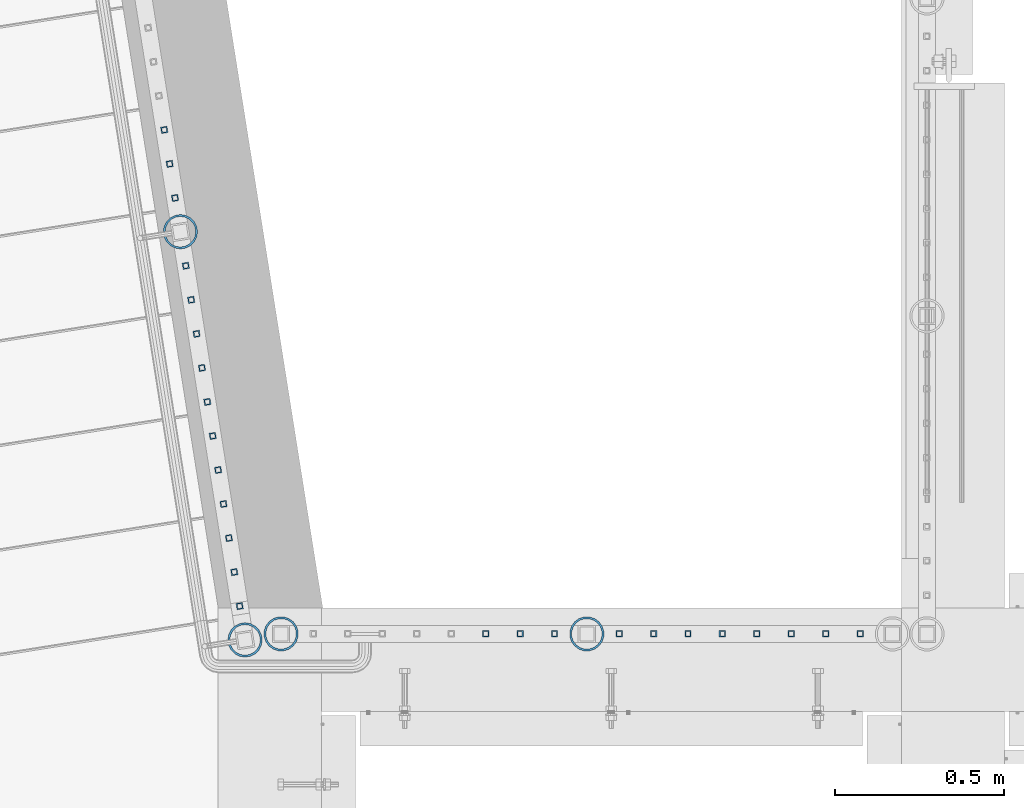
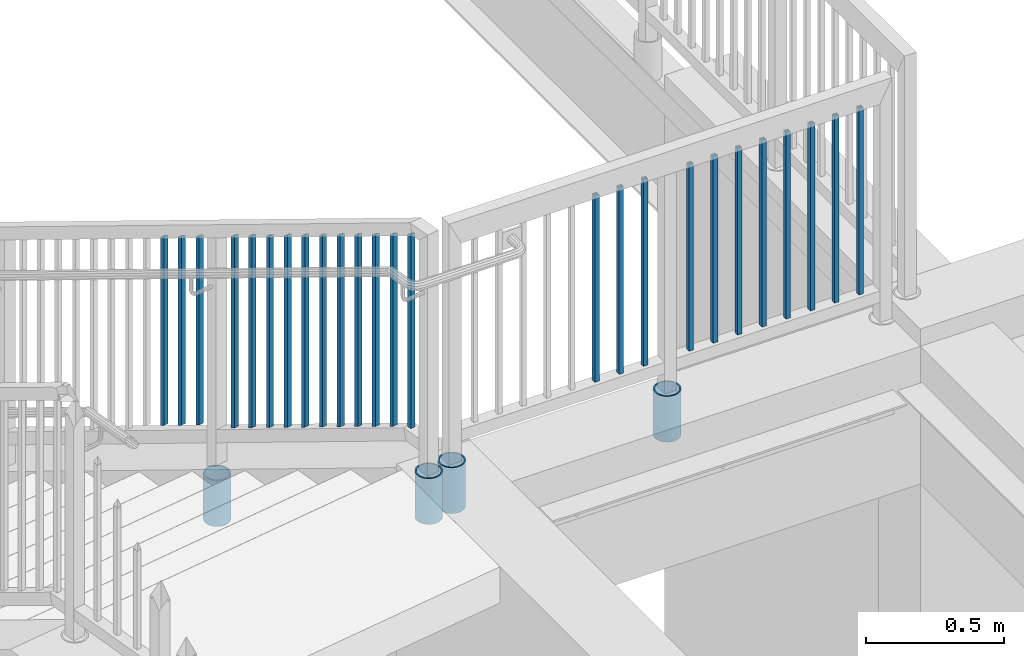
# One storey, part 211 of 975: 29 columns.
"""IFC2X3 building model written with IfcOpenShell, lengths in millimetres."""

from ifc_helpers import new_model, si_unit, frame, origin_with_axes, place, context, subcontext, project, spatial, faceted_brep, material, type_object, element, save


model = new_model("IFC2X3")

# Units and contexts
model_context = context("Model", 3, precision=1e-05, world=origin_with_axes())
body_context = subcontext(model_context, "Body", "Model", "MODEL_VIEW")
ifc_project = project(units=[si_unit("LENGTHUNIT", "METRE", prefix="MILLI"), si_unit("AREAUNIT", "SQUARE_METRE"), si_unit("VOLUMEUNIT", "CUBIC_METRE"), si_unit("MASSUNIT", "GRAM", prefix="KILO"), si_unit("TIMEUNIT", "SECOND"), si_unit("PLANEANGLEUNIT", "RADIAN"), si_unit("SOLIDANGLEUNIT", "STERADIAN"), si_unit("THERMODYNAMICTEMPERATUREUNIT", "DEGREE_CELSIUS"), si_unit("LUMINOUSINTENSITYUNIT", "LUMEN")], contexts=[model_context])

# Site, building, storey
site_placement = place(None, origin_with_axes())
site = spatial("IfcSite", under=ifc_project, at=site_placement, CompositionType="ELEMENT")
building_placement = place(site_placement, origin_with_axes())
building = spatial("IfcBuilding", under=site, at=building_placement, Name="Undefined", CompositionType="ELEMENT")
storey_placement = place(building_placement, origin_with_axes())
storey = spatial("IfcBuildingStorey", under=building, at=storey_placement, Name="Undefined", CompositionType="ELEMENT", Elevation=0.0)

# Columns
ifc_material_1 = material()
column_type_1 = type_object("IfcColumnType", Name="HSS3/4X3/4X.120_TUBES", PredefinedType="NOTDEFINED")
for number, where, z_axis, x_axis, name in (
    (1, (992.846988509125, 20672.3889447702, 4178.3000105335), (1.0, 0.0, 0.0), (0.0, 0.0, 1.0), "PICKET"),
    (2, (891.246988509125, 20672.3889447702, 4178.3000105335), (1.0, 0.0, 0.0), (0.0, 0.0, 1.0), "PICKET"),
    (3, (789.646988509125, 20672.3889447702, 4178.3000105335), (1.0, 0.0, 0.0), (0.0, 0.0, 1.0), "PICKET"),
    (4, (1183.56432177817, 20672.3889447702, 4178.3000162462), (1.0, 0.0, 0.0), (0.0, 0.0, 1.0), "PICKET"),
    (5, (1894.76432177817, 20672.3889447702, 4178.3000162462), (1.0, 0.0, 0.0), (0.0, 0.0, 1.0), "PICKET"),
    (6, (1793.16432177817, 20672.3889447702, 4178.3000162462), (1.0, 0.0, 0.0), (0.0, 0.0, 1.0), "PICKET"),
    (7, (1691.56432177817, 20672.3889447702, 4178.3000162462), (1.0, 0.0, 0.0), (0.0, 0.0, 1.0), "PICKET"),
    (8, (1589.96432177817, 20672.3889447702, 4178.3000162462), (1.0, 0.0, 0.0), (0.0, 0.0, 1.0), "PICKET"),
    (9, (1488.36432177817, 20672.3889447702, 4178.3000162462), (1.0, 0.0, 0.0), (0.0, 0.0, 1.0), "PICKET"),
    (10, (1386.76432177817, 20672.3889447702, 4178.3000162462), (1.0, 0.0, 0.0), (0.0, 0.0, 1.0), "PICKET"),
    (11, (1285.16432177817, 20672.3889447702, 4178.3000162462), (1.0, 0.0, 0.0), (0.0, 0.0, 1.0), "PICKET"),
):
    element("IfcColumn", number, at=place(storey_placement, frame(where, z_axis=z_axis, x_axis=x_axis)), inside=storey, type_object=column_type_1, material=ifc_material_1, Name=name, ObjectType="HSS3/4X3/4X.120_TUBES", context=body_context, shape_type="Brep", body=[
        faceted_brep([(0.0, 6.34999999998763, -6.34999999998763), (0.0, -6.35000000000582, -6.34999999998763), (825.49997943247, -6.35000000000582, -6.34999999998763), (825.49997943247, 6.34999999998763, -6.34999999998763), (0.0, -6.34999999998763, 6.34999999998763), (825.49997943247, -6.34999999998763, 6.34999999998763), (0.0, 6.35000000000946, 6.34999999998763), (825.49997943247, 6.35000000000946, 6.34999999998763), (0.0, 9.52499999997963, -9.52499999997963), (0.0, 9.52500000000873, 9.5249999999869), (825.49997943247, 9.52500000000873, 9.5249999999869), (825.49997943247, 9.52499999997963, -9.52499999997963), (0.0, -9.52499999997963, 9.52499999998327), (825.49997943247, -9.52499999997963, 9.52499999998327), (0.0, -9.52500000000873, -9.5249999999869), (825.49997943247, -9.52500000000873, -9.5249999999869)], [[[0, 1, 2, 3]], [[1, 4, 5, 2]], [[4, 6, 7, 5]], [[6, 0, 3, 7]], [[8, 9, 10, 11]], [[9, 12, 13, 10]], [[12, 14, 15, 13]], [[14, 8, 11, 15]], [[13, 15, 11, 10], [5, 7, 3, 2]], [[14, 12, 9, 8], [6, 4, 1, 0]]]),
    ])
for number, where, z_axis, x_axis, name in (
    (12, (-126.611819510976, 21958.5335003285, 3525.90359784302), (-0.987688340611262, -0.156434464938429, 0.0), (0.0, 0.0, 1.0), "PICKET"),
    (13, (-142.51441013771, 22058.9385051127, 3469.78070058239), (-0.987688340611262, -0.156434464938429, 0.0), (0.0, 0.0, 1.0), "PICKET"),
    (14, (-158.417000764441, 22159.3435098969, 3413.65780332177), (-0.987688340611262, -0.156434464938429, 0.0), (0.0, 0.0, 1.0), "PICKET"),
):
    element("IfcColumn", number, at=place(storey_placement, frame(where, z_axis=z_axis, x_axis=x_axis)), inside=storey, type_object=column_type_1, material=ifc_material_1, Name=name, ObjectType="HSS3/4X3/4X.120_TUBES", context=body_context, shape_type="Brep", body=[
        faceted_brep([(-3.50571911954194, 6.34999999999491, -6.34999999999809), (3.50573940444565, -6.34999999999491, -6.34999999999991), (838.195107257512, -6.34999999999491, -6.35000000000082), (831.183648729623, 6.34999999999491, -6.34999999999945), (3.50571915819046, -6.34999999998763, 6.34999999999786), (838.195107270213, -6.34999999999127, 6.34999999999809), (-3.50573936579713, 6.34999999999854, 6.34999999999968), (831.183648742323, 6.35000000000218, 6.34999999999945), (-5.25857868897492, 9.5249999999869, -9.52499999999668), (-5.25860905835771, 9.52500000000146, 9.52499999999964), (829.430784113527, 9.52499999999782, 9.52499999999964), (829.430784094476, 9.52499999999054, -9.52499999999827), (5.25857872762344, -9.52499999998327, 9.52499999999645), (839.947971905361, -9.5249999999869, 9.52499999999736), (5.25860909700623, -9.52499999999418, -9.52499999999986), (839.947971886309, -9.52499999999782, -9.525000000001)], [[[0, 1, 2, 3]], [[1, 4, 5, 2]], [[4, 6, 7, 5]], [[6, 0, 3, 7]], [[8, 9, 10, 11]], [[9, 12, 13, 10]], [[12, 14, 15, 13]], [[14, 8, 11, 15]], [[13, 15, 11, 10], [5, 7, 3, 2]], [[14, 12, 9, 8], [6, 4, 1, 0]]]),
    ])
column_1_placement = place(storey_placement, frame((64.1130818819122, 20754.3438757387, 4178.2999918998), z_axis=(-0.987688340611262, -0.156434464938429, 0.0), x_axis=(0.0, 0.0, 1.0)))
element("IfcColumn", 15, at=column_1_placement, inside=storey, type_object=column_type_1, material=ifc_material_1, Name="PICKET", ObjectType="HSS3/4X3/4X.120_TUBES", context=body_context, shape_type="Brep", body=[
    faceted_brep([(0.0, 6.34999999998763, -6.34999999998763), (0.0, -6.35000000000582, -6.34999999998763), (858.898731993615, -6.34999999999491, -6.35000000000082), (851.887273465725, 6.34999999999491, -6.349999999999), (0.0, -6.34999999998763, 6.34999999998763), (858.898732006316, -6.34999999999127, 6.34999999999809), (0.0, 6.35000000000946, 6.34999999998763), (851.887273478426, 6.34999999999854, 6.34999999999991), (0.0, 9.52499999997963, -9.52499999997963), (0.0, 9.52500000000873, 9.5249999999869), (850.134408849629, 9.52499999999782, 9.52499999999964), (850.134408830578, 9.5249999999869, -9.52499999999827), (0.0, -9.52499999997963, 9.52499999998327), (860.651596641464, -9.52499999998327, 9.52499999999782), (0.0, -9.52500000000873, -9.5249999999869), (860.651596622412, -9.52499999999782, -9.52500000000055)], [[[0, 1, 2, 3]], [[1, 4, 5, 2]], [[4, 6, 7, 5]], [[6, 0, 3, 7]], [[8, 9, 10, 11]], [[9, 12, 13, 10]], [[12, 14, 15, 13]], [[14, 8, 11, 15]], [[13, 15, 11, 10], [5, 7, 3, 2]], [[14, 12, 9, 8], [6, 4, 1, 0]]]),
])
for number, where, z_axis, x_axis, name in (
    (16, (48.2104912543862, 20854.7488805279, 4142.88071913312), (-0.987688340611262, -0.156434464938429, 0.0), (0.0, 0.0, 1.0), "PICKET"),
    (17, (32.3079006276537, 20955.153885312, 4086.7578218725), (-0.987688340611262, -0.156434464938429, 0.0), (0.0, 0.0, 1.0), "PICKET"),
    (18, (16.4053100009201, 21055.5588900962, 4030.63492461188), (-0.987688340611262, -0.156434464938429, 0.0), (0.0, 0.0, 1.0), "PICKET"),
    (19, (0.502719374190065, 21155.9638948803, 3974.51202735126), (-0.987688340611262, -0.156434464938429, 0.0), (0.0, 0.0, 1.0), "PICKET"),
    (20, (-15.3998712525421, 21256.3688996645, 3918.38913009064), (-0.987688340611262, -0.156434464938429, 0.0), (0.0, 0.0, 1.0), "PICKET"),
    (21, (-31.3024618794072, 21356.7739044495, 3862.26623283002), (-0.987688340611262, -0.156434464938429, 0.0), (0.0, 0.0, 1.0), "PICKET"),
    (22, (-47.2050525061386, 21457.1789092336, 3806.1433355694), (-0.987688340611262, -0.156434464938429, 0.0), (0.0, 0.0, 1.0), "PICKET"),
    (23, (-63.10764313287, 21557.5839140178, 3750.02043830879), (-0.987688340611262, -0.156434464938429, 0.0), (0.0, 0.0, 1.0), "PICKET"),
    (24, (-79.0102337596018, 21657.9889188019, 3693.89754104817), (-0.987688340611262, -0.156434464938429, 0.0), (0.0, 0.0, 1.0), "PICKET"),
    (25, (-94.9128243863345, 21758.3939235861, 3637.77464378755), (-0.987688340611262, -0.156434464938429, 0.0), (0.0, 0.0, 1.0), "PICKET"),
):
    element("IfcColumn", number, at=place(storey_placement, frame(where, z_axis=z_axis, x_axis=x_axis)), inside=storey, type_object=column_type_1, material=ifc_material_1, Name=name, ObjectType="HSS3/4X3/4X.120_TUBES", context=body_context, shape_type="Brep", body=[
        faceted_brep([(-17.9916664943412, 6.34999999999491, -6.34999999999945), (-10.9802079664514, -6.34999999999127, -6.35000000000173), (838.195107257512, -6.34999999999491, -6.35000000000082), (831.183648729623, 6.34999999999491, -6.34999999999945), (-10.9802079664505, -6.34999999998763, 6.34999999999764), (838.195107270213, -6.34999999999127, 6.34999999999809), (-17.9916664943403, 6.35000000000218, 6.34999999999945), (831.183648742323, 6.35000000000218, 6.34999999999945), (-19.7445311263136, 9.52499999999054, -9.52499999999918), (-19.7445311263118, 9.52500000000146, 9.52499999999918), (829.430784113527, 9.52499999999782, 9.52499999999964), (829.430784094476, 9.52499999999054, -9.52499999999827), (-9.22734333447806, -9.52499999998327, 9.52499999999691), (839.947971905361, -9.5249999999869, 9.52499999999736), (-9.22734333447897, -9.52499999999418, -9.525000000001), (839.947971886309, -9.52499999999782, -9.525000000001)], [[[0, 1, 2, 3]], [[1, 4, 5, 2]], [[4, 6, 7, 5]], [[6, 0, 3, 7]], [[8, 9, 10, 11]], [[9, 12, 13, 10]], [[12, 14, 15, 13]], [[14, 8, 11, 15]], [[13, 15, 11, 10], [5, 7, 3, 2]], [[14, 12, 9, 8], [6, 4, 1, 0]]]),
    ])
ifc_material_2 = material(Name="STEEL/A53")
column_type_2 = type_object("IfcColumnType", Name="PIPE3-1/2STD", PredefinedType="NOTDEFINED")
column_2_placement = place(storey_placement, frame((186.288333380988, 20672.4249713359, 3835.40001649977), z_axis=(-0.707106781186601, 0.707106781186494, 2.36468622460961e-14), x_axis=(0.0, 0.0, 1.0)))
element("IfcColumn", 26, at=column_2_placement, inside=storey, type_object=column_type_2, material=ifc_material_2, ObjectType="PIPE3-1/2STD", context=body_context, shape_type="Brep", body=[
    faceted_brep([(0.0, -45.0595999999932, 1.45519152283669e-11), (0.0, -42.8542262016344, 13.924182159768), (203.199999999991, -42.8542262017145, 13.9241821598171), (203.19999999999, -45.0596000000478, 5.82076609134674e-11), (0.0, -36.45398215971, 26.4853683542424), (203.199999999993, -36.45398215981, 26.4853683542988), (0.0, -26.4853683541623, 36.45398215979), (203.199999999995, -26.4853683542788, 36.4539821598537), (0.0, -13.9241821596988, 42.8542262017108), (203.199999999998, -13.9241821598262, 42.8542262017836), (0.0, 3.63797880709171e-11, 45.0596000000514), (203.2, -9.27684595808387e-11, 45.0596000001387), (0.0, 13.9241821597716, 42.8542262017036), (203.200000000003, 13.9241821596443, 42.8542262017927), (0.0, 26.4853683542242, 36.4539821597718), (203.200000000006, 26.4853683541096, 36.4539821598701), (0.0, 36.4539821597537, 26.4853683542206), (203.200000000008, 36.4539821596554, 26.4853683543224), (0.0, 42.8542262016563, 13.9241821597425), (203.200000000009, 42.8542262015817, 13.9241821598443), (0.0, 45.0595999999932, -1.09139364212751e-11), (203.200000000009, 45.0595999999423, 8.9130480773747e-11), (0.0, 42.8542262016344, -13.9241821597643), (203.200000000008, 42.854226201609, -13.9241821596697), (0.0, 36.45398215971, -26.4853683542387), (203.200000000007, 36.4539821597045, -26.4853683541514), (0.0, 26.4853683541623, -36.4539821597864), (203.200000000004, 26.4853683541733, -36.4539821597064), (0.0, 13.9241821596988, -42.8542262017072), (203.200000000002, 13.9241821597225, -42.8542262016381), (0.0, -3.63797880709171e-11, -45.0596000000478), (203.199999999999, -9.09494701772928e-12, -45.0595999999914), (0.0, -13.9241821597716, -42.8542262016963), (203.199999999996, -13.9241821597479, -42.8542262016472), (0.0, -26.4853683542242, -36.4539821597682), (203.199999999993, -26.4853683542133, -36.4539821597227), (0.0, -36.4539821597537, -26.4853683542169), (203.199999999992, -36.4539821597609, -26.4853683541751), (0.0, -42.8542262016563, -13.9241821597352), (203.199999999991, -42.8542262016872, -13.924182159697), (0.0, -50.799999999992, 1.81898940354586e-11), (0.0, -48.3136710278013, -15.6980633142484), (203.199999999989, -48.313671027825, -15.6980633142139), (203.199999999989, -50.8000000000466, 5.63886715099216e-11), (0.0, -41.0980633142644, -29.8594908164741), (203.19999999999, -41.0980633142663, -29.8594908164414), (0.0, -29.859490816485, -41.0980633142826), (203.199999999993, -29.8594908164687, -41.0980633142426), (0.0, -15.6980633142848, -48.313671027845), (203.199999999995, -15.6980633142539, -48.313671027794), (0.0, -4.36557456851006e-11, -50.8000000000575), (203.199999999998, -7.27595761418343e-12, -50.7999999999993), (0.0, 15.6980633142011, -48.3136710278523), (203.200000000002, 15.6980633142375, -48.3136710277831), (0.0, 29.8594908164159, -41.0980633143045), (203.200000000005, 29.8594908164378, -41.0980633142226), (0.0, 41.0980633142135, -29.8594908165032), (203.200000000008, 41.0980633142171, -29.8594908164141), (0.0, 48.3136710277722, -15.6980633142775), (203.200000000009, 48.3136710277504, -15.6980633141811), (0.0, 50.799999999992, -1.45519152283669e-11), (203.20000000001, 50.7999999999411, 9.09494701772928e-11), (0.0, 48.313671027794, 15.6980633142521), (203.20000000001, 48.3136710277213, 15.6980633143594), (0.0, 41.0980633142644, 29.8594908164814), (203.200000000008, 41.0980633141626, 29.8594908165887), (0.0, 29.859490816485, 41.0980633142863), (203.200000000007, 29.8594908163632, 41.0980633143899), (0.0, 15.6980633142848, 48.3136710278486), (203.200000000004, 15.6980633141484, 48.3136710279414), (0.0, 4.00177668780088e-11, 50.8000000000611), (203.200000000001, -9.82254277914762e-11, 50.8000000001466), (0.0, -15.6980633142011, 48.3136710278559), (203.199999999997, -15.698063314343, 48.3136710279305), (0.0, -29.8594908164159, 41.0980633143081), (203.199999999994, -29.8594908165433, 41.0980633143681), (0.0, -41.0980633142171, 29.8594908165069), (203.199999999992, -41.0980633143226, 29.8594908165596), (0.0, -48.3136710277722, 15.6980633142812), (203.19999999999, -48.3136710278559, 15.6980633143285)], [[[0, 1, 2, 3]], [[1, 4, 5, 2]], [[4, 6, 7, 5]], [[6, 8, 9, 7]], [[8, 10, 11, 9]], [[10, 12, 13, 11]], [[12, 14, 15, 13]], [[14, 16, 17, 15]], [[16, 18, 19, 17]], [[18, 20, 21, 19]], [[20, 22, 23, 21]], [[22, 24, 25, 23]], [[24, 26, 27, 25]], [[26, 28, 29, 27]], [[28, 30, 31, 29]], [[30, 32, 33, 31]], [[32, 34, 35, 33]], [[34, 36, 37, 35]], [[36, 38, 39, 37]], [[38, 0, 3, 39]], [[40, 41, 42, 43]], [[41, 44, 45, 42]], [[44, 46, 47, 45]], [[46, 48, 49, 47]], [[48, 50, 51, 49]], [[50, 52, 53, 51]], [[52, 54, 55, 53]], [[54, 56, 57, 55]], [[56, 58, 59, 57]], [[58, 60, 61, 59]], [[60, 62, 63, 61]], [[62, 64, 65, 63]], [[64, 66, 67, 65]], [[66, 68, 69, 67]], [[68, 70, 71, 69]], [[70, 72, 73, 71]], [[72, 74, 75, 73]], [[74, 76, 77, 75]], [[76, 78, 79, 77]], [[78, 40, 43, 79]], [[45, 47, 49, 51, 53, 55, 57, 59, 61, 63, 65, 67, 69, 71, 73, 75, 77, 79, 43, 42], [5, 7, 9, 11, 13, 15, 17, 19, 21, 23, 25, 27, 29, 31, 33, 35, 37, 39, 3, 2]], [[78, 76, 74, 72, 70, 68, 66, 64, 62, 60, 58, 56, 54, 52, 50, 48, 46, 44, 41, 40], [38, 36, 34, 32, 30, 28, 26, 24, 22, 20, 18, 16, 14, 12, 10, 8, 6, 4, 1, 0]]]),
])
column_3_placement = place(storey_placement, frame((1088.20566786924, 20672.3889673828, 3835.40001649977), z_axis=(-0.707106781186601, 0.707106781186494, 2.36468622460961e-14), x_axis=(0.0, 0.0, 1.0)))
element("IfcColumn", 27, at=column_3_placement, inside=storey, type_object=column_type_2, material=ifc_material_2, ObjectType="PIPE3-1/2STD", context=body_context, shape_type="Brep", body=[
    faceted_brep([(0.0, -45.0595999999932, 1.45519152283669e-11), (0.0, -42.8542262016344, 13.924182159768), (203.199999999991, -42.8542262017145, 13.9241821598171), (203.19999999999, -45.0596000000478, 5.82076609134674e-11), (0.0, -36.45398215971, 26.4853683542424), (203.199999999993, -36.45398215981, 26.4853683542988), (0.0, -26.4853683541623, 36.45398215979), (203.199999999995, -26.4853683542788, 36.4539821598537), (0.0, -13.9241821596988, 42.8542262017108), (203.199999999998, -13.9241821598262, 42.8542262017836), (0.0, 3.63797880709171e-11, 45.0596000000514), (203.2, -9.27684595808387e-11, 45.0596000001387), (0.0, 13.9241821597716, 42.8542262017036), (203.200000000003, 13.9241821596443, 42.8542262017927), (0.0, 26.4853683542242, 36.4539821597718), (203.200000000006, 26.4853683541096, 36.4539821598701), (0.0, 36.4539821597537, 26.4853683542206), (203.200000000008, 36.4539821596554, 26.4853683543224), (0.0, 42.8542262016563, 13.9241821597425), (203.200000000009, 42.8542262015817, 13.9241821598443), (0.0, 45.0595999999932, -1.09139364212751e-11), (203.200000000009, 45.0595999999423, 8.9130480773747e-11), (0.0, 42.8542262016344, -13.9241821597643), (203.200000000008, 42.854226201609, -13.9241821596697), (0.0, 36.45398215971, -26.4853683542387), (203.200000000007, 36.4539821597045, -26.4853683541514), (0.0, 26.4853683541623, -36.4539821597864), (203.200000000004, 26.4853683541733, -36.4539821597064), (0.0, 13.9241821596988, -42.8542262017072), (203.200000000002, 13.9241821597225, -42.8542262016381), (0.0, -3.63797880709171e-11, -45.0596000000478), (203.199999999999, -9.09494701772928e-12, -45.0595999999914), (0.0, -13.9241821597716, -42.8542262016963), (203.199999999996, -13.9241821597479, -42.8542262016472), (0.0, -26.4853683542242, -36.4539821597682), (203.199999999993, -26.4853683542133, -36.4539821597227), (0.0, -36.4539821597537, -26.4853683542169), (203.199999999992, -36.4539821597609, -26.4853683541751), (0.0, -42.8542262016563, -13.9241821597352), (203.199999999991, -42.8542262016872, -13.924182159697), (0.0, -50.799999999992, 1.81898940354586e-11), (0.0, -48.3136710278013, -15.6980633142484), (203.199999999989, -48.313671027825, -15.6980633142139), (203.199999999989, -50.8000000000466, 5.63886715099216e-11), (0.0, -41.0980633142644, -29.8594908164741), (203.19999999999, -41.0980633142663, -29.8594908164414), (0.0, -29.859490816485, -41.0980633142826), (203.199999999993, -29.8594908164687, -41.0980633142426), (0.0, -15.6980633142848, -48.313671027845), (203.199999999995, -15.6980633142539, -48.313671027794), (0.0, -4.36557456851006e-11, -50.8000000000575), (203.199999999998, -7.27595761418343e-12, -50.7999999999993), (0.0, 15.6980633142011, -48.3136710278523), (203.200000000002, 15.6980633142375, -48.3136710277831), (0.0, 29.8594908164159, -41.0980633143045), (203.200000000005, 29.8594908164378, -41.0980633142226), (0.0, 41.0980633142135, -29.8594908165032), (203.200000000008, 41.0980633142171, -29.8594908164141), (0.0, 48.3136710277722, -15.6980633142775), (203.200000000009, 48.3136710277504, -15.6980633141811), (0.0, 50.799999999992, -1.45519152283669e-11), (203.20000000001, 50.7999999999411, 9.09494701772928e-11), (0.0, 48.313671027794, 15.6980633142521), (203.20000000001, 48.3136710277213, 15.6980633143594), (0.0, 41.0980633142644, 29.8594908164814), (203.200000000008, 41.0980633141626, 29.8594908165887), (0.0, 29.859490816485, 41.0980633142863), (203.200000000007, 29.8594908163632, 41.0980633143899), (0.0, 15.6980633142848, 48.3136710278486), (203.200000000004, 15.6980633141484, 48.3136710279414), (0.0, 4.00177668780088e-11, 50.8000000000611), (203.200000000001, -9.82254277914762e-11, 50.8000000001466), (0.0, -15.6980633142011, 48.3136710278559), (203.199999999997, -15.698063314343, 48.3136710279305), (0.0, -29.8594908164159, 41.0980633143081), (203.199999999994, -29.8594908165433, 41.0980633143681), (0.0, -41.0980633142171, 29.8594908165069), (203.199999999992, -41.0980633143226, 29.8594908165596), (0.0, -48.3136710277722, 15.6980633142812), (203.19999999999, -48.3136710278559, 15.6980633143285)], [[[0, 1, 2, 3]], [[1, 4, 5, 2]], [[4, 6, 7, 5]], [[6, 8, 9, 7]], [[8, 10, 11, 9]], [[10, 12, 13, 11]], [[12, 14, 15, 13]], [[14, 16, 17, 15]], [[16, 18, 19, 17]], [[18, 20, 21, 19]], [[20, 22, 23, 21]], [[22, 24, 25, 23]], [[24, 26, 27, 25]], [[26, 28, 29, 27]], [[28, 30, 31, 29]], [[30, 32, 33, 31]], [[32, 34, 35, 33]], [[34, 36, 37, 35]], [[36, 38, 39, 37]], [[38, 0, 3, 39]], [[40, 41, 42, 43]], [[41, 44, 45, 42]], [[44, 46, 47, 45]], [[46, 48, 49, 47]], [[48, 50, 51, 49]], [[50, 52, 53, 51]], [[52, 54, 55, 53]], [[54, 56, 57, 55]], [[56, 58, 59, 57]], [[58, 60, 61, 59]], [[60, 62, 63, 61]], [[62, 64, 65, 63]], [[64, 66, 67, 65]], [[66, 68, 69, 67]], [[68, 70, 71, 69]], [[70, 72, 73, 71]], [[72, 74, 75, 73]], [[74, 76, 77, 75]], [[76, 78, 79, 77]], [[78, 40, 43, 79]], [[45, 47, 49, 51, 53, 55, 57, 59, 61, 63, 65, 67, 69, 71, 73, 75, 77, 79, 43, 42], [5, 7, 9, 11, 13, 15, 17, 19, 21, 23, 25, 27, 29, 31, 33, 35, 37, 39, 3, 2]], [[78, 76, 74, 72, 70, 68, 66, 64, 62, 60, 58, 56, 54, 52, 50, 48, 46, 44, 41, 40], [38, 36, 34, 32, 30, 28, 26, 24, 22, 20, 18, 16, 14, 12, 10, 8, 6, 4, 1, 0]]]),
])
column_4_placement = place(storey_placement, frame((-110.816149070635, 21858.7988122083, 3162.29993752722), z_axis=(0.587785252279345, 0.809016994384486, -8.09014238711826e-10), x_axis=(0.0, 0.0, 1.0)))
element("IfcColumn", 28, at=column_4_placement, inside=storey, type_object=column_type_2, material=ifc_material_2, ObjectType="PIPE3-1/2STD", context=body_context, shape_type="Brep", body=[
    faceted_brep([(0.0, -45.0595999999932, 1.45519152283669e-11), (0.0, -42.8542262016344, 13.924182159768), (203.199999999991, -42.8542262017145, 13.9241821598171), (203.19999999999, -45.0596000000478, 5.82076609134674e-11), (0.0, -36.45398215971, 26.4853683542424), (203.199999999993, -36.45398215981, 26.4853683542988), (0.0, -26.4853683541623, 36.45398215979), (203.199999999995, -26.4853683542788, 36.4539821598537), (0.0, -13.9241821596988, 42.8542262017108), (203.199999999998, -13.9241821598262, 42.8542262017836), (0.0, 3.63797880709171e-11, 45.0596000000514), (203.2, -9.27684595808387e-11, 45.0596000001387), (0.0, 13.9241821597716, 42.8542262017036), (203.200000000003, 13.9241821596443, 42.8542262017927), (0.0, 26.4853683542242, 36.4539821597718), (203.200000000006, 26.4853683541096, 36.4539821598701), (0.0, 36.4539821597537, 26.4853683542206), (203.200000000008, 36.4539821596554, 26.4853683543224), (0.0, 42.8542262016563, 13.9241821597425), (203.200000000009, 42.8542262015817, 13.9241821598443), (0.0, 45.0595999999932, -1.09139364212751e-11), (203.200000000009, 45.0595999999423, 8.9130480773747e-11), (0.0, 42.8542262016344, -13.9241821597643), (203.200000000008, 42.854226201609, -13.9241821596697), (0.0, 36.45398215971, -26.4853683542387), (203.200000000007, 36.4539821597045, -26.4853683541514), (0.0, 26.4853683541623, -36.4539821597864), (203.200000000004, 26.4853683541733, -36.4539821597064), (0.0, 13.9241821596988, -42.8542262017072), (203.200000000002, 13.9241821597225, -42.8542262016381), (0.0, -3.63797880709171e-11, -45.0596000000478), (203.199999999999, -9.09494701772928e-12, -45.0595999999914), (0.0, -13.9241821597716, -42.8542262016963), (203.199999999996, -13.9241821597479, -42.8542262016472), (0.0, -26.4853683542242, -36.4539821597682), (203.199999999993, -26.4853683542133, -36.4539821597227), (0.0, -36.4539821597537, -26.4853683542169), (203.199999999992, -36.4539821597609, -26.4853683541751), (0.0, -42.8542262016563, -13.9241821597352), (203.199999999991, -42.8542262016872, -13.924182159697), (0.0, -50.799999999992, 1.81898940354586e-11), (0.0, -48.3136710278013, -15.6980633142484), (203.199999999989, -48.313671027825, -15.6980633142139), (203.199999999989, -50.8000000000466, 5.63886715099216e-11), (0.0, -41.0980633142644, -29.8594908164741), (203.19999999999, -41.0980633142663, -29.8594908164414), (0.0, -29.859490816485, -41.0980633142826), (203.199999999993, -29.8594908164687, -41.0980633142426), (0.0, -15.6980633142848, -48.313671027845), (203.199999999995, -15.6980633142539, -48.313671027794), (0.0, -4.36557456851006e-11, -50.8000000000575), (203.199999999998, -7.27595761418343e-12, -50.7999999999993), (0.0, 15.6980633142011, -48.3136710278523), (203.200000000002, 15.6980633142375, -48.3136710277831), (0.0, 29.8594908164159, -41.0980633143045), (203.200000000005, 29.8594908164378, -41.0980633142226), (0.0, 41.0980633142135, -29.8594908165032), (203.200000000008, 41.0980633142171, -29.8594908164141), (0.0, 48.3136710277722, -15.6980633142775), (203.200000000009, 48.3136710277504, -15.6980633141811), (0.0, 50.799999999992, -1.45519152283669e-11), (203.20000000001, 50.7999999999411, 9.09494701772928e-11), (0.0, 48.313671027794, 15.6980633142521), (203.20000000001, 48.3136710277213, 15.6980633143594), (0.0, 41.0980633142644, 29.8594908164814), (203.200000000008, 41.0980633141626, 29.8594908165887), (0.0, 29.859490816485, 41.0980633142863), (203.200000000007, 29.8594908163632, 41.0980633143899), (0.0, 15.6980633142848, 48.3136710278486), (203.200000000004, 15.6980633141484, 48.3136710279414), (0.0, 4.00177668780088e-11, 50.8000000000611), (203.200000000001, -9.82254277914762e-11, 50.8000000001466), (0.0, -15.6980633142011, 48.3136710278559), (203.199999999997, -15.698063314343, 48.3136710279305), (0.0, -29.8594908164159, 41.0980633143081), (203.199999999994, -29.8594908165433, 41.0980633143681), (0.0, -41.0980633142171, 29.8594908165069), (203.199999999992, -41.0980633143226, 29.8594908165596), (0.0, -48.3136710277722, 15.6980633142812), (203.19999999999, -48.3136710278559, 15.6980633143285)], [[[0, 1, 2, 3]], [[1, 4, 5, 2]], [[4, 6, 7, 5]], [[6, 8, 9, 7]], [[8, 10, 11, 9]], [[10, 12, 13, 11]], [[12, 14, 15, 13]], [[14, 16, 17, 15]], [[16, 18, 19, 17]], [[18, 20, 21, 19]], [[20, 22, 23, 21]], [[22, 24, 25, 23]], [[24, 26, 27, 25]], [[26, 28, 29, 27]], [[28, 30, 31, 29]], [[30, 32, 33, 31]], [[32, 34, 35, 33]], [[34, 36, 37, 35]], [[36, 38, 39, 37]], [[38, 0, 3, 39]], [[40, 41, 42, 43]], [[41, 44, 45, 42]], [[44, 46, 47, 45]], [[46, 48, 49, 47]], [[48, 50, 51, 49]], [[50, 52, 53, 51]], [[52, 54, 55, 53]], [[54, 56, 57, 55]], [[56, 58, 59, 57]], [[58, 60, 61, 59]], [[60, 62, 63, 61]], [[62, 64, 65, 63]], [[64, 66, 67, 65]], [[66, 68, 69, 67]], [[68, 70, 71, 69]], [[70, 72, 73, 71]], [[72, 74, 75, 73]], [[74, 76, 77, 75]], [[76, 78, 79, 77]], [[78, 40, 43, 79]], [[45, 47, 49, 51, 53, 55, 57, 59, 61, 63, 65, 67, 69, 71, 73, 75, 77, 79, 43, 42], [5, 7, 9, 11, 13, 15, 17, 19, 21, 23, 25, 27, 29, 31, 33, 35, 37, 39, 3, 2]], [[78, 76, 74, 72, 70, 68, 66, 64, 62, 60, 58, 56, 54, 52, 50, 48, 46, 44, 41, 40], [38, 36, 34, 32, 30, 28, 26, 24, 22, 20, 18, 16, 14, 12, 10, 8, 6, 4, 1, 0]]]),
])
column_5_placement = place(storey_placement, frame((79.9087505992718, 20654.609187241, 3835.40003518347), z_axis=(0.587785252279345, 0.809016994384486, -8.09014238711826e-10), x_axis=(0.0, 0.0, 1.0)))
element("IfcColumn", 29, at=column_5_placement, inside=storey, type_object=column_type_2, material=ifc_material_2, ObjectType="PIPE3-1/2STD", context=body_context, shape_type="Brep", body=[
    faceted_brep([(0.0, -45.0595999999932, 1.45519152283669e-11), (0.0, -42.8542262016344, 13.924182159768), (203.199999999991, -42.8542262017145, 13.9241821598171), (203.19999999999, -45.0596000000478, 5.82076609134674e-11), (0.0, -36.45398215971, 26.4853683542424), (203.199999999993, -36.45398215981, 26.4853683542988), (0.0, -26.4853683541623, 36.45398215979), (203.199999999995, -26.4853683542788, 36.4539821598537), (0.0, -13.9241821596988, 42.8542262017108), (203.199999999998, -13.9241821598262, 42.8542262017836), (0.0, 3.63797880709171e-11, 45.0596000000514), (203.2, -9.27684595808387e-11, 45.0596000001387), (0.0, 13.9241821597716, 42.8542262017036), (203.200000000003, 13.9241821596443, 42.8542262017927), (0.0, 26.4853683542242, 36.4539821597718), (203.200000000006, 26.4853683541096, 36.4539821598701), (0.0, 36.4539821597537, 26.4853683542206), (203.200000000008, 36.4539821596554, 26.4853683543224), (0.0, 42.8542262016563, 13.9241821597425), (203.200000000009, 42.8542262015817, 13.9241821598443), (0.0, 45.0595999999932, -1.09139364212751e-11), (203.200000000009, 45.0595999999423, 8.9130480773747e-11), (0.0, 42.8542262016344, -13.9241821597643), (203.200000000008, 42.854226201609, -13.9241821596697), (0.0, 36.45398215971, -26.4853683542387), (203.200000000007, 36.4539821597045, -26.4853683541514), (0.0, 26.4853683541623, -36.4539821597864), (203.200000000004, 26.4853683541733, -36.4539821597064), (0.0, 13.9241821596988, -42.8542262017072), (203.200000000002, 13.9241821597225, -42.8542262016381), (0.0, -3.63797880709171e-11, -45.0596000000478), (203.199999999999, -9.09494701772928e-12, -45.0595999999914), (0.0, -13.9241821597716, -42.8542262016963), (203.199999999996, -13.9241821597479, -42.8542262016472), (0.0, -26.4853683542242, -36.4539821597682), (203.199999999993, -26.4853683542133, -36.4539821597227), (0.0, -36.4539821597537, -26.4853683542169), (203.199999999992, -36.4539821597609, -26.4853683541751), (0.0, -42.8542262016563, -13.9241821597352), (203.199999999991, -42.8542262016872, -13.924182159697), (0.0, -50.799999999992, 1.81898940354586e-11), (0.0, -48.3136710278013, -15.6980633142484), (203.199999999989, -48.313671027825, -15.6980633142139), (203.199999999989, -50.8000000000466, 5.63886715099216e-11), (0.0, -41.0980633142644, -29.8594908164741), (203.19999999999, -41.0980633142663, -29.8594908164414), (0.0, -29.859490816485, -41.0980633142826), (203.199999999993, -29.8594908164687, -41.0980633142426), (0.0, -15.6980633142848, -48.313671027845), (203.199999999995, -15.6980633142539, -48.313671027794), (0.0, -4.36557456851006e-11, -50.8000000000575), (203.199999999998, -7.27595761418343e-12, -50.7999999999993), (0.0, 15.6980633142011, -48.3136710278523), (203.200000000002, 15.6980633142375, -48.3136710277831), (0.0, 29.8594908164159, -41.0980633143045), (203.200000000005, 29.8594908164378, -41.0980633142226), (0.0, 41.0980633142135, -29.8594908165032), (203.200000000008, 41.0980633142171, -29.8594908164141), (0.0, 48.3136710277722, -15.6980633142775), (203.200000000009, 48.3136710277504, -15.6980633141811), (0.0, 50.799999999992, -1.45519152283669e-11), (203.20000000001, 50.7999999999411, 9.09494701772928e-11), (0.0, 48.313671027794, 15.6980633142521), (203.20000000001, 48.3136710277213, 15.6980633143594), (0.0, 41.0980633142644, 29.8594908164814), (203.200000000008, 41.0980633141626, 29.8594908165887), (0.0, 29.859490816485, 41.0980633142863), (203.200000000007, 29.8594908163632, 41.0980633143899), (0.0, 15.6980633142848, 48.3136710278486), (203.200000000004, 15.6980633141484, 48.3136710279414), (0.0, 4.00177668780088e-11, 50.8000000000611), (203.200000000001, -9.82254277914762e-11, 50.8000000001466), (0.0, -15.6980633142011, 48.3136710278559), (203.199999999997, -15.698063314343, 48.3136710279305), (0.0, -29.8594908164159, 41.0980633143081), (203.199999999994, -29.8594908165433, 41.0980633143681), (0.0, -41.0980633142171, 29.8594908165069), (203.199999999992, -41.0980633143226, 29.8594908165596), (0.0, -48.3136710277722, 15.6980633142812), (203.19999999999, -48.3136710278559, 15.6980633143285)], [[[0, 1, 2, 3]], [[1, 4, 5, 2]], [[4, 6, 7, 5]], [[6, 8, 9, 7]], [[8, 10, 11, 9]], [[10, 12, 13, 11]], [[12, 14, 15, 13]], [[14, 16, 17, 15]], [[16, 18, 19, 17]], [[18, 20, 21, 19]], [[20, 22, 23, 21]], [[22, 24, 25, 23]], [[24, 26, 27, 25]], [[26, 28, 29, 27]], [[28, 30, 31, 29]], [[30, 32, 33, 31]], [[32, 34, 35, 33]], [[34, 36, 37, 35]], [[36, 38, 39, 37]], [[38, 0, 3, 39]], [[40, 41, 42, 43]], [[41, 44, 45, 42]], [[44, 46, 47, 45]], [[46, 48, 49, 47]], [[48, 50, 51, 49]], [[50, 52, 53, 51]], [[52, 54, 55, 53]], [[54, 56, 57, 55]], [[56, 58, 59, 57]], [[58, 60, 61, 59]], [[60, 62, 63, 61]], [[62, 64, 65, 63]], [[64, 66, 67, 65]], [[66, 68, 69, 67]], [[68, 70, 71, 69]], [[70, 72, 73, 71]], [[72, 74, 75, 73]], [[74, 76, 77, 75]], [[76, 78, 79, 77]], [[78, 40, 43, 79]], [[45, 47, 49, 51, 53, 55, 57, 59, 61, 63, 65, 67, 69, 71, 73, 75, 77, 79, 43, 42], [5, 7, 9, 11, 13, 15, 17, 19, 21, 23, 25, 27, 29, 31, 33, 35, 37, 39, 3, 2]], [[78, 76, 74, 72, 70, 68, 66, 64, 62, 60, 58, 56, 54, 52, 50, 48, 46, 44, 41, 40], [38, 36, 34, 32, 30, 28, 26, 24, 22, 20, 18, 16, 14, 12, 10, 8, 6, 4, 1, 0]]]),
])

save(model, "model.ifc")
